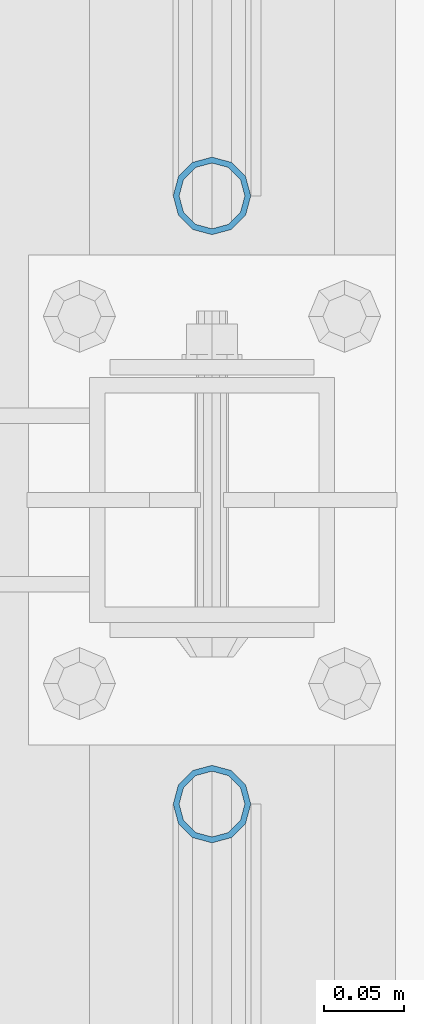
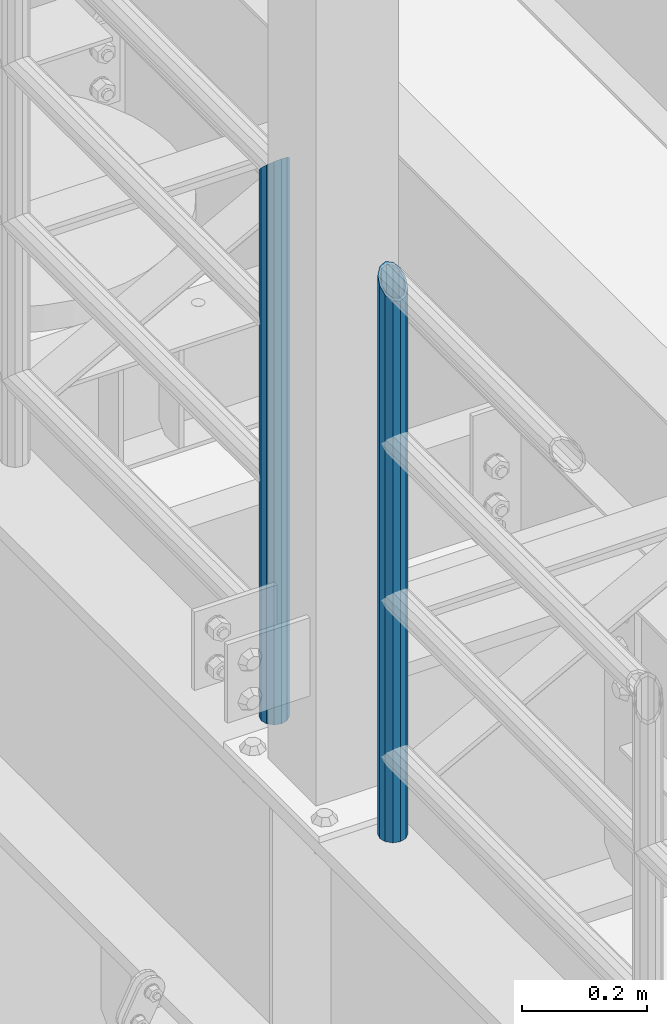
# One storey, part 621 of 1876: 2 columns, 2 elements without a shape of their own.
"""IFC2X3 building model written with IfcOpenShell, lengths in millimetres."""

from ifc_helpers import new_model, si_unit, frame, origin_with_axes, place, context, subcontext, project, spatial, faceted_brep, material, type_object, element, aggregate, save


model = new_model("IFC2X3")

# Units and contexts
model_context = context("Model", 3, precision=1e-05, world=origin_with_axes())
body_context = subcontext(model_context, "Body", "Model", "MODEL_VIEW")
ifc_project = project(units=[si_unit("LENGTHUNIT", "METRE", prefix="MILLI"), si_unit("AREAUNIT", "SQUARE_METRE"), si_unit("VOLUMEUNIT", "CUBIC_METRE"), si_unit("MASSUNIT", "GRAM", prefix="KILO"), si_unit("TIMEUNIT", "SECOND"), si_unit("PLANEANGLEUNIT", "RADIAN"), si_unit("SOLIDANGLEUNIT", "STERADIAN"), si_unit("THERMODYNAMICTEMPERATUREUNIT", "DEGREE_CELSIUS"), si_unit("LUMINOUSINTENSITYUNIT", "LUMEN")], contexts=[model_context])

# Site, building, storey
site_placement = place(None, origin_with_axes())
site = spatial("IfcSite", under=ifc_project, at=site_placement, CompositionType="ELEMENT")
building_placement = place(site_placement, origin_with_axes())
building = spatial("IfcBuilding", under=site, at=building_placement, Name="Undefined", CompositionType="ELEMENT")
storey_placement = place(building_placement, origin_with_axes())
storey = spatial("IfcBuildingStorey", under=building, at=storey_placement, Name="Undefined", CompositionType="ELEMENT", Elevation=0.0)

# Assembly, column
assembly_1_placement = place(storey_placement, origin_with_axes())
assembly_1 = element("IfcElementAssembly", 1, at=assembly_1_placement, inside=storey, Name="RAIL", AssemblyPlace="NOTDEFINED", PredefinedType="RIGID_FRAME")
ifc_material = material()
column_type = type_object("IfcColumnType", Name="PIPE1-1/2SCH40", PredefinedType="NOTDEFINED")
column_1_placement = place(assembly_1_placement, frame((-1.81898940354586e-12, -2350.77, 8153.4), z_axis=(0.0, 1.0, 0.0), x_axis=(0.0, 0.0, 1.0)))
column_1 = element("IfcColumn", 2, at=column_1_placement, type_object=column_type, material=ifc_material, Name="POST", ObjectType="PIPE1-1/2SCH40", context=body_context, shape_type="Brep", body=[
    faceted_brep([(0.0, -20.4469999999999, 0.0), (0.0, -17.7076214311803, 10.2235000000001), (1066.1015, -17.7076214311803, 10.2235000000001), (1076.325, -20.4469999999999, 0.0), (0.0, -10.2235000000001, 17.7076214311801), (1058.61737856882, -10.2235000000001, 17.7076214311801), (-1.45519152283669e-11, 0.0, 20.4470000000001), (1055.878, 0.0, 20.4470000000001), (0.0, 10.2235000000001, 17.7076214311801), (1058.61737856882, 10.2235000000001, 17.7076214311801), (0.0, 17.7076214311803, 10.2235000000001), (1066.1015, 17.7076214311803, 10.2235000000001), (0.0, 20.4469999999999, 0.0), (1076.325, 20.4469999999999, 0.0), (0.0, 17.7076214311803, -10.2235000000001), (1086.5485, 17.7076214311803, -10.2235000000001), (0.0, 10.2235000000001, -17.7076214311801), (1094.03262143118, 10.2235000000001, -17.7076214311801), (-1.45519152283669e-11, 0.0, -20.4470000000001), (1096.772, 0.0, -20.4470000000001), (0.0, -10.2235000000001, -17.7076214311801), (1094.03262143118, -10.2235000000001, -17.7076214311801), (0.0, -17.7076214311803, -10.2235000000001), (1086.5485, -17.7076214311803, -10.2235000000001), (0.0, -24.1299999999992, 0.0), (0.0, -20.8971929933184, -12.0649999999996), (1088.39, -20.8971929933184, -12.0649999999996), (1076.325, -24.1300000000001, 0.0), (0.0, -12.0650000000001, -20.8971929933186), (1097.22219299332, -12.0650000000001, -20.8971929933186), (-1.45519152283669e-11, 0.0, -24.130000000001), (1100.455, 0.0, -24.1300000000001), (0.0, 12.0650000000001, -20.8971929933186), (1097.22219299332, 12.0650000000001, -20.8971929933186), (0.0, 20.8971929933184, -12.0649999999996), (1088.39, 20.8971929933184, -12.0649999999996), (0.0, 24.1299999999992, 0.0), (1076.325, 24.1300000000001, 0.0), (0.0, 20.8971929933184, 12.0649999999996), (1064.26, 20.8971929933184, 12.0649999999996), (0.0, 12.0650000000001, 20.8971929933186), (1055.42780700668, 12.0650000000001, 20.8971929933186), (-1.45519152283669e-11, 0.0, 24.130000000001), (1052.195, 0.0, 24.1300000000001), (0.0, -12.0650000000001, 20.8971929933186), (1055.42780700668, -12.0650000000001, 20.8971929933186), (0.0, -20.8971929933184, 12.0649999999996), (1064.26, -20.8971929933184, 12.0649999999996)], [[[0, 1, 2, 3]], [[1, 4, 5, 2]], [[4, 6, 7, 5]], [[6, 8, 9, 7]], [[8, 10, 11, 9]], [[10, 12, 13, 11]], [[12, 14, 15, 13]], [[14, 16, 17, 15]], [[16, 18, 19, 17]], [[18, 20, 21, 19]], [[20, 22, 23, 21]], [[22, 0, 3, 23]], [[24, 25, 26, 27]], [[25, 28, 29, 26]], [[28, 30, 31, 29]], [[30, 32, 33, 31]], [[32, 34, 35, 33]], [[34, 36, 37, 35]], [[36, 38, 39, 37]], [[38, 40, 41, 39]], [[40, 42, 43, 41]], [[42, 44, 45, 43]], [[44, 46, 47, 45]], [[46, 24, 27, 47]], [[29, 31, 33, 35, 37, 39, 41, 43, 45, 47, 27, 26], [5, 7, 9, 11, 13, 15, 17, 19, 21, 23, 3, 2]], [[46, 44, 42, 40, 38, 36, 34, 32, 30, 28, 25, 24], [22, 20, 18, 16, 14, 12, 10, 8, 6, 4, 1, 0]]]),
])
aggregate(assembly_1, [column_1])

assembly_2_placement = place(storey_placement, origin_with_axes())
assembly_2 = element("IfcElementAssembly", 3, at=assembly_2_placement, inside=storey, Name="RAIL", AssemblyPlace="NOTDEFINED", PredefinedType="RIGID_FRAME")
column_2_placement = place(assembly_2_placement, frame((-1.81898940354586e-12, -2729.3062, 8153.4), z_axis=(0.0, 1.0, 0.0), x_axis=(0.0, 0.0, 1.0)))
column_2 = element("IfcColumn", 4, at=column_2_placement, type_object=column_type, material=ifc_material, Name="POST", ObjectType="PIPE1-1/2SCH40", context=body_context, shape_type="Brep", body=[
    faceted_brep([(0.0, -20.4469999999999, 0.0), (0.0, -17.7076214311803, 10.2235000000001), (1086.54849999999, -17.7076214311801, 10.2235000000001), (1076.325, -20.4469999999999, 0.0), (0.0, -10.2235000000001, 17.7076214311801), (1094.03262143117, -10.2235000000001, 17.7076214311801), (-1.45519152283669e-11, 0.0, 20.4470000000001), (1096.77199999999, 0.0, 20.4470000000001), (0.0, 10.2235000000001, 17.7076214311801), (1094.03262143117, 10.2235000000001, 17.7076214311801), (0.0, 17.7076214311803, 10.2235000000001), (1086.54849999999, 17.7076214311801, 10.2235000000001), (0.0, 20.4469999999999, 0.0), (1076.325, 20.4469999999999, 0.0), (0.0, 17.7076214311803, -10.2235000000001), (1066.10149999999, 17.7076214311801, -10.2235000000001), (0.0, 10.2235000000001, -17.7076214311801), (1058.61737856881, 10.2235000000001, -17.7076214311801), (-1.45519152283669e-11, 0.0, -20.4470000000001), (1055.87799999999, 0.0, -20.4470000000001), (0.0, -10.2235000000001, -17.7076214311801), (1058.61737856881, -10.2235000000001, -17.7076214311801), (0.0, -17.7076214311803, -10.2235000000001), (1066.10149999999, -17.7076214311801, -10.2235000000001), (0.0, -24.1299999999992, 0.0), (0.0, -20.8971929933184, -12.0649999999996), (1064.25999999999, -20.8971929933186, -12.0649999999996), (1076.325, -24.1300000000001, 0.0), (0.0, -12.0650000000001, -20.8971929933186), (1055.42780700667, -12.0649999999996, -20.8971929933186), (-1.45519152283669e-11, 0.0, -24.130000000001), (1052.19499999999, 0.0, -24.1300000000001), (0.0, 12.0650000000001, -20.8971929933186), (1055.42780700667, 12.0649999999996, -20.8971929933186), (0.0, 20.8971929933184, -12.0649999999996), (1064.25999999999, 20.8971929933186, -12.0649999999996), (0.0, 24.1299999999992, 0.0), (1076.325, 24.1300000000001, 0.0), (0.0, 20.8971929933184, 12.0649999999996), (1088.38999999999, 20.8971929933186, 12.0649999999996), (0.0, 12.0650000000001, 20.8971929933186), (1097.22219299331, 12.0649999999996, 20.8971929933186), (-1.45519152283669e-11, 0.0, 24.130000000001), (1100.45499999999, 0.0, 24.1300000000001), (0.0, -12.0650000000001, 20.8971929933186), (1097.22219299331, -12.0649999999996, 20.8971929933186), (0.0, -20.8971929933184, 12.0649999999996), (1088.38999999999, -20.8971929933186, 12.0649999999996)], [[[0, 1, 2, 3]], [[1, 4, 5, 2]], [[4, 6, 7, 5]], [[6, 8, 9, 7]], [[8, 10, 11, 9]], [[10, 12, 13, 11]], [[12, 14, 15, 13]], [[14, 16, 17, 15]], [[16, 18, 19, 17]], [[18, 20, 21, 19]], [[20, 22, 23, 21]], [[22, 0, 3, 23]], [[24, 25, 26, 27]], [[25, 28, 29, 26]], [[28, 30, 31, 29]], [[30, 32, 33, 31]], [[32, 34, 35, 33]], [[34, 36, 37, 35]], [[36, 38, 39, 37]], [[38, 40, 41, 39]], [[40, 42, 43, 41]], [[42, 44, 45, 43]], [[44, 46, 47, 45]], [[46, 24, 27, 47]], [[29, 31, 33, 35, 37, 39, 41, 43, 45, 47, 27, 26], [5, 7, 9, 11, 13, 15, 17, 19, 21, 23, 3, 2]], [[46, 44, 42, 40, 38, 36, 34, 32, 30, 28, 25, 24], [22, 20, 18, 16, 14, 12, 10, 8, 6, 4, 1, 0]]]),
])
aggregate(assembly_2, [column_2])

save(model, "model.ifc")
